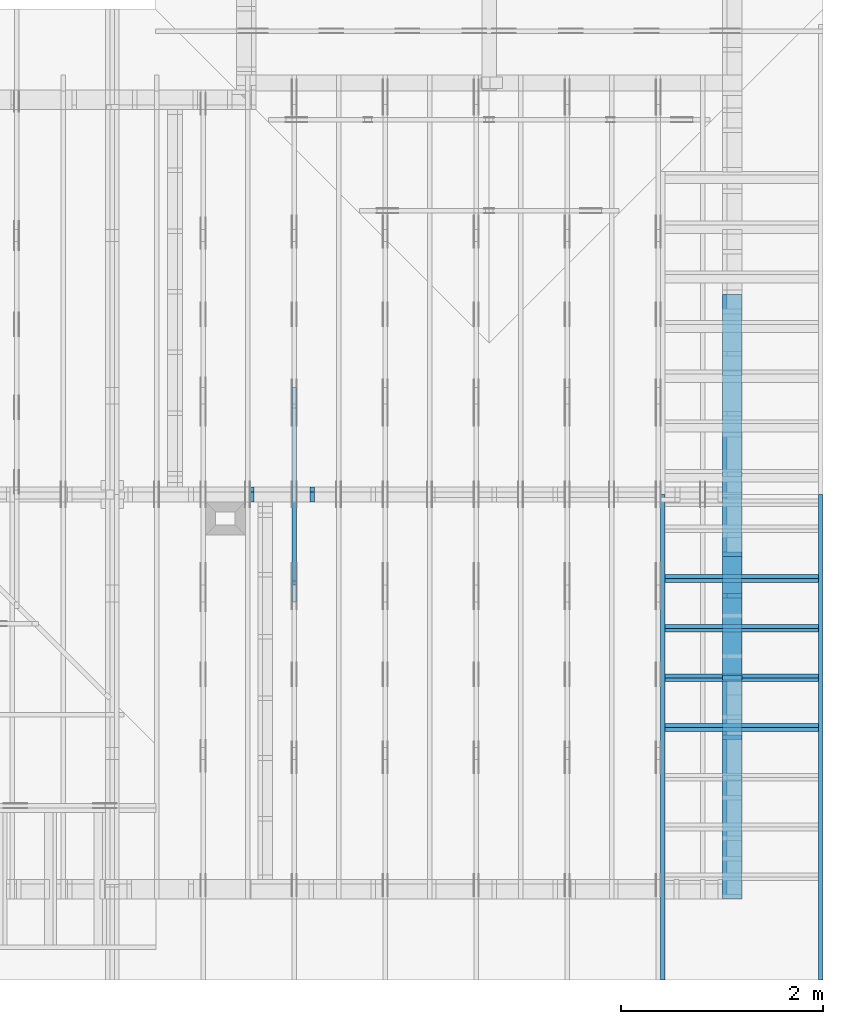
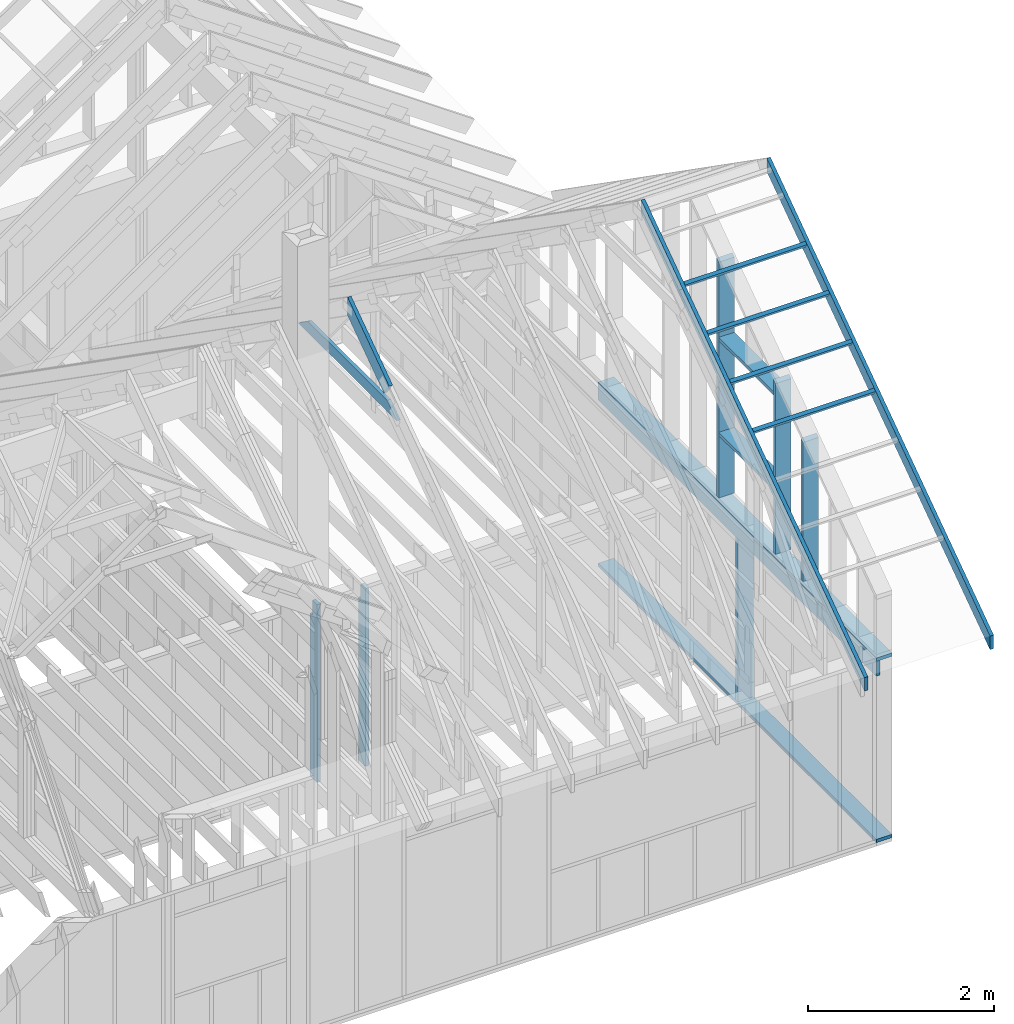
# One storey, part 23 of 70: 19 members, 5 elements without a shape of their own.
"""IFC2X3 building model written with IfcOpenShell, lengths in millimetres."""

from ifc_helpers import new_model, si_unit, frame, origin, origin_with_axes, origin_2d, place, context, project, spatial, faceted_brep, element, aggregate, save


model = new_model("IFC2X3")

# Units and contexts
model_context = context("Model", 3, precision=1e-05, world=origin())
plan_context = context("Plan", 2, precision=1e-05, world=origin_2d())
ifc_project = project(units=[si_unit("LENGTHUNIT", "METRE", prefix="MILLI"), si_unit("AREAUNIT", "SQUARE_METRE"), si_unit("VOLUMEUNIT", "CUBIC_METRE"), si_unit("SOLIDANGLEUNIT", "STERADIAN"), si_unit("PLANEANGLEUNIT", "RADIAN"), si_unit("MASSUNIT", "GRAM"), si_unit("TIMEUNIT", "SECOND"), si_unit("THERMODYNAMICTEMPERATUREUNIT", "DEGREE_CELSIUS"), si_unit("LUMINOUSINTENSITYUNIT", "LUMEN")], contexts=[model_context, plan_context])

# Site, building, storey
site_placement = place(None, origin_with_axes())
site = spatial("IfcSite", under=ifc_project, at=site_placement, CompositionType="ELEMENT")
building_placement = place(site_placement, origin_with_axes())
building = spatial("IfcBuilding", under=site, at=building_placement, Name="Layout 1", CompositionType="ELEMENT")
storey_placement = place(building_placement, origin_with_axes())
storey = spatial("IfcBuildingStorey", under=building, at=storey_placement, Name="Storey 1", CompositionType="ELEMENT", Elevation=0.0)

# Assembly, members
assembly_1_placement = place(storey_placement, frame((12000.0, 0.0, -2470.0), z_axis=(1.0, -6.123031769111886e-17, 6.123031769111886e-17), x_axis=(6.123031769111886e-17, 1.0, 0.0)))
assembly_1 = element("IfcElementAssembly", 1, at=assembly_1_placement, inside=storey, Name="VE5", AssemblyPlace="FACTORY", PredefinedType="NOTDEFINED")
member_1_placement = place(assembly_1_placement, frame((1.457281561048629e-13, 2425.0, -195.0), z_axis=(0.0, 0.0, 1.0), x_axis=(1.0, 0.0, 0.0)))
member_1 = element("IfcMember", 2, at=member_1_placement, Name="P1", context=model_context, shape_type="Brep", body=[
    faceted_brep([(5980.0, 45.0, 195.0), (2.755364296100349e-15, 45.0, 195.0), (0.0, 0.0, 195.0), (5980.0, 0.0, 195.0), (2.755364296100349e-15, 45.0, 3.3742366240998092e-31), (5980.0, 45.0, 7.323145995857816e-13), (5980.0, 0.0, 7.323145995857816e-13), (0.0, 0.0, 0.0), (0.0, 0.0, 0.0), (1.1939911949768178e-14, -1.462169203776584e-30, 195.0), (1.7450640541968876e-14, 45.0, 195.0), (5.510728592200698e-15, 45.0, -1.6871183120499046e-31), (5980.0, -1.0984718993786724e-12, 6.725978337372286e-29), (5980.0, -1.0865319874289042e-12, 195.0), (2.193253805664876e-30, 1.1939911949768178e-14, 195.0), (0.0, 0.0, 0.0), (5980.0, 45.0, 0.0), (5980.0, 45.0, 195.0), (5980.0, 0.0, 195.0), (5980.0, 0.0, 0.0), (2.755364296100349e-15, 45.0, 0.0), (2.755364296100348e-15, 44.999999999999986, 195.0), (5980.0, 44.99999999999962, 195.0), (5980.0, 44.99999999999963, -2.2482535798798836e-29)], [[[0, 1, 2, 3]], [[4, 5, 6, 7]], [[8, 9, 10, 11]], [[12, 13, 14, 15]], [[16, 17, 18, 19]], [[20, 21, 22, 23]]]),
])
member_2_placement = place(assembly_1_placement, frame((5980.0, 90.0, -195.0), z_axis=(0.0, 0.0, 1.0), x_axis=(-1.0, 1.2246063538223773e-16, 0.0)))
member_2 = element("IfcMember", 3, at=member_2_placement, Name="P1", context=model_context, shape_type="Brep", body=[
    faceted_brep([(5980.0, 45.00000000000074, 195.0), (0.0, 45.00000000000074, 195.0), (0.0, 0.0, 195.0), (5980.0, 0.0, 195.0), (0.0, 45.00000000000074, 0.0), (5980.0, 45.00000000000074, 7.323145995857816e-13), (5980.0, 0.0, 7.323145995857816e-13), (0.0, 0.0, 0.0), (0.0, 0.0, 0.0), (1.1939911949768178e-14, -1.462169203776584e-30, 195.0), (1.7450640541968876e-14, 45.00000000000001, 195.0), (5.5107285922006985e-15, 45.00000000000001, -3.3742366240998097e-31), (5980.0, -1.0984718993786724e-12, 1.1250681111517883e-28), (5980.0, -1.0865319874289042e-12, 195.0), (2.193253805664876e-30, 1.1939911949768178e-14, 195.0), (0.0, 0.0, 0.0), (5980.0, 45.00000000000074, 0.0), (5980.0, 45.00000000000074, 195.0), (5980.0, 7.389644451905042e-13, 195.0), (5980.0, 7.389644451905042e-13, 0.0), (0.0, 45.00000000000001, 0.0), (1.5777218104420236e-30, 44.99999999999999, 195.0), (5980.0, 45.00000000000096, 195.0), (5980.0, 45.000000000000966, 1.3805065841367707e-29)], [[[0, 1, 2, 3]], [[4, 5, 6, 7]], [[8, 9, 10, 11]], [[12, 13, 14, 15]], [[16, 17, 18, 19]], [[20, 21, 22, 23]]]),
])
member_3_placement = place(assembly_1_placement, frame((1.3378824415499132e-13, 2229.9999999981374, -195.0), z_axis=(0.0, 0.0, 1.0), x_axis=(1.0, 0.0, 0.0)))
member_3 = element("IfcMember", 4, at=member_3_placement, Name="L1", context=model_context, shape_type="Brep", body=[
    faceted_brep([(5980.0, 195.00000000186265, 45.0), (1.1939911949871576e-14, 195.00000000186265, 45.0), (0.0, 0.0, 45.0), (5980.0, 0.0, 45.0), (1.1939911949871576e-14, 195.00000000186265, 1.4621692037892461e-30), (5980.0, 195.00000000186265, 7.323145995857816e-13), (5980.0, 0.0, 7.323145995857816e-13), (0.0, 0.0, 0.0), (0.0, 0.0, 0.0), (2.755364296100349e-15, -3.3742366240998092e-31, 45.0), (2.6635188195864806e-14, 195.00000000186265, 45.0), (2.3879823899764457e-14, 195.00000000186265, -7.310846018959277e-31), (5980.0, 1.86317026748279e-09, -3.2153157385149134e-29), (5980.0, 1.8631730228470863e-09, 45.0), (-8.584804067855881e-28, 2.755364296100349e-15, 45.0), (0.0, 0.0, 0.0), (5980.0, 195.00000000186265, 0.0), (5980.0, 195.00000000186265, 45.0), (5980.0, 1.862645149230957e-09, 45.0), (5980.0, 1.862645149230957e-09, 0.0), (1.1939911949871576e-14, 195.00000000186265, 0.0), (1.1939911949871576e-14, 195.00000000186265, 45.0), (5980.0, 195.00000000186228, 45.0), (5980.0, 195.00000000186228, -2.208810534618833e-29)], [[[0, 1, 2, 3]], [[4, 5, 6, 7]], [[8, 9, 10, 11]], [[12, 13, 14, 15]], [[16, 17, 18, 19]], [[20, 21, 22, 23]]]),
])
member_4_placement = place(assembly_1_placement, frame((2977.5000000018335, 2425.0, -195.0), z_axis=(0.0, 0.0, 1.0), x_axis=(-1.836909530733566e-16, -1.0, 0.0)))
member_4 = element("IfcMember", 5, at=member_4_placement, Name="S11", context=model_context, shape_type="Brep", body=[
    faceted_brep([(0.0, 44.99999999998545, 45.0), (195.00000000186265, 44.99999999998545, 45.00000000000002), (195.00000000186265, 0.0, 45.00000000000002), (0.0, 0.0, 45.0), (195.00000000186265, 0.0, 0.0), (195.00000000186265, -3.3742366240998092e-31, 45.0), (195.00000000186265, 44.99999999998545, 45.0), (195.00000000186265, 44.99999999998545, 0.0), (2.755364296100349e-15, -3.3742366240998092e-31, 45.0), (1.1939911949768178e-14, -1.462169203776584e-30, 195.0), (1.7450640541967096e-14, 44.99999999998545, 195.00000000000003), (8.266092888299264e-15, 44.99999999998545, 45.0), (2335.0, -4.2891837542628763e-13, 2.626280839091018e-29), (2335.0, -4.1697846347651946e-13, 195.0), (2.193253805664876e-30, 1.1939911949768178e-14, 195.0), (5.061354936149714e-31, 2.755364296100349e-15, 45.0), (195.00000000186265, -3.306437155354634e-14, 45.0), (195.00000000186265, -3.5819735849646686e-14, 2.193253805685826e-30), (-1.6871183120499046e-31, 44.99999999998545, 45.0), (-7.31084601888292e-31, 44.999999999985434, 195.0), (2335.0, 44.99999999998529, 195.0), (2335.0, 44.999999999985306, -8.67746995743113e-30), (195.00000000186265, 44.999999999985434, -7.888609052210118e-31), (195.00000000186265, 44.999999999985434, 45.0), (2335.0, 44.9999999999859, 2.842170943040401e-14), (2335.0, 44.9999999999859, 195.0), (2335.0, 4.547473508864641e-13, 195.0), (2335.0, 4.547473508864641e-13, 0.0), (2335.0, 44.9999999999859, 195.0), (0.0, 44.9999999999859, 195.0), (0.0, 0.0, 195.0), (2335.0, 0.0, 195.0), (195.00000000186265, 44.99999999998545, 2.3879823899764457e-14), (2335.0, 44.99999999998545, 2.859455836175251e-13), (2335.0, 4.547473508864641e-13, 2.859455836175251e-13), (195.00000000186265, 4.547473508864641e-13, 2.3879823899764457e-14)], [[[0, 1, 2, 3]], [[4, 5, 6, 7]], [[8, 9, 10, 11]], [[12, 13, 14, 15, 16, 17]], [[18, 19, 20, 21, 22, 23]], [[24, 25, 26, 27]], [[28, 29, 30, 31]], [[32, 33, 34, 35]]]),
])
aggregate(assembly_1, [member_1, member_2, member_3, member_4])

assembly_2_placement = place(storey_placement, frame((-48.55339059327651, 3927.500000000001, -2470.0), z_axis=(0.0, -1.0, 6.123031769111886e-17), x_axis=(1.0, 0.0, 0.0)))
assembly_2 = element("IfcElementAssembly", 6, at=assembly_2_placement, inside=storey, Name="VE8", AssemblyPlace="FACTORY", PredefinedType="NOTDEFINED")
member_5_placement = place(assembly_2_placement, frame((7177.5000000018335, 2425.0, -145.0), z_axis=(0.0, 0.0, 1.0), x_axis=(-1.836909530733566e-16, -1.0, 0.0)))
member_5 = element("IfcMember", 7, at=member_5_placement, Name="B3", context=model_context, shape_type="Brep", body=[
    faceted_brep([(0.0, 45.0, 45.0), (195.00000000186265, 45.0, 45.00000000000002), (195.00000000186265, 1.4551915228366852e-11, 45.00000000000002), (0.0, 1.4551915228366852e-11, 45.0), (195.00000000186265, 1.3642420526593924e-11, 0.0), (195.00000000186265, 1.3642420526593924e-11, 45.0), (195.00000000186265, 45.0, 45.0), (195.00000000186265, 45.0, 0.0), (2.755364296102131e-15, 1.4551915228366852e-11, 45.0), (8.878396065214018e-15, 1.4551915228366852e-11, 145.0), (1.4389124657412933e-14, 45.0, 145.0), (8.266092888301046e-15, 45.0, 45.0), (2335.0, 1.4122996852940564e-11, 2.626280839091018e-29), (2335.0, 1.4131875249005776e-11, 145.0), (1.6308810349815745e-30, 1.4560793624432064e-11, 145.0), (5.061354936149714e-31, 1.4554670592662952e-11, 45.0), (195.00000000186265, 1.4518850856813305e-11, 45.0), (195.00000000186265, 1.4516095492517205e-11, 2.193253805685862e-30), (-1.6871183120499046e-31, 45.0, 45.0), (-5.436270116605248e-31, 44.99999999999999, 145.0), (2335.0, 44.99999999999985, 145.0), (2335.0, 44.99999999999986, -8.67746995743113e-30), (195.00000000186265, 44.999999999999986, -7.888609052210118e-31), (195.00000000186265, 44.999999999999986, 45.0), (2335.0, 45.0, 2.842170943040401e-14), (2335.0, 45.0, 145.0), (2335.0, 0.0, 145.0), (2335.0, 0.0, 0.0), (2335.0, 45.0, 145.0), (0.0, 45.0, 145.0), (0.0, 1.4551915228366852e-11, 145.0), (2335.0, 1.4551915228366852e-11, 145.0), (195.00000000186265, 45.0, 2.3879823899764457e-14), (2335.0, 45.0, 2.859455836175251e-13), (2335.0, 0.0, 2.859455836175251e-13), (195.00000000186265, 0.0, 2.3879823899764457e-14)], [[[0, 1, 2, 3]], [[4, 5, 6, 7]], [[8, 9, 10, 11]], [[12, 13, 14, 15, 16, 17]], [[18, 19, 20, 21, 22, 23]], [[24, 25, 26, 27]], [[28, 29, 30, 31]], [[32, 33, 34, 35]]]),
])
member_6_placement = place(assembly_2_placement, frame((7777.500000001819, 2425.0, -145.0), z_axis=(0.0, 0.0, 1.0), x_axis=(-1.836909530733566e-16, -1.0, 0.0)))
member_6 = element("IfcMember", 8, at=member_6_placement, Name="S42", context=model_context, shape_type="Brep", body=[
    faceted_brep([(0.0, 45.000000000029104, 45.0), (195.00000000186265, 45.000000000029104, 45.00000000000002), (195.00000000186265, 1.4551915228366852e-11, 45.00000000000002), (0.0, 1.4551915228366852e-11, 45.0), (195.00000000186265, 1.3642420526593924e-11, 0.0), (195.00000000186265, 1.3642420526593924e-11, 45.0), (195.00000000186265, 45.000000000026375, 45.0), (195.00000000186265, 45.000000000026375, 0.0), (2.755364296102131e-15, 1.4551915228366852e-11, 45.0), (8.878396065214018e-15, 1.4551915228366852e-11, 145.0), (1.43891246574165e-14, 45.000000000029104, 145.0), (8.26609288830461e-15, 45.000000000029104, 45.0), (2335.0, 1.4122996852940564e-11, 2.626280839091018e-29), (2335.0, 1.4131875249005776e-11, 145.0), (1.6308810349815745e-30, 1.4560793624432064e-11, 145.0), (5.061354936149714e-31, 1.4554670592662952e-11, 45.0), (195.00000000186265, 1.4518850856813305e-11, 45.0), (195.00000000186265, 1.4516095492517205e-11, 2.193253805685862e-30), (-1.6871183120499046e-31, 45.000000000026375, 45.0), (-5.436270116605248e-31, 45.00000000002637, 145.0), (2335.0, 45.000000000026226, 145.0), (2335.0, 45.00000000002623, -8.67746995743113e-30), (195.00000000186265, 45.00000000002636, -7.888609052210118e-31), (195.00000000186265, 45.00000000002636, 45.0), (2335.0, 45.0, 2.842170943040401e-14), (2335.0, 45.0, 145.0), (2335.0, 0.0, 145.0), (2335.0, 0.0, 0.0), (2335.0, 45.0, 145.0), (0.0, 45.0, 145.0), (0.0, 1.4551915228366852e-11, 145.0), (2335.0, 1.4551915228366852e-11, 145.0), (195.00000000186265, 45.000000000026375, 2.3879823899764457e-14), (2335.0, 45.000000000026375, 2.859455836175251e-13), (2335.0, 0.0, 2.859455836175251e-13), (195.00000000186265, 0.0, 2.3879823899764457e-14)], [[[0, 1, 2, 3]], [[4, 5, 6, 7]], [[8, 9, 10, 11]], [[12, 13, 14, 15, 16, 17]], [[18, 19, 20, 21, 22, 23]], [[24, 25, 26, 27]], [[28, 29, 30, 31]], [[32, 33, 34, 35]]]),
])
aggregate(assembly_2, [member_5, member_6])

assembly_3_placement = place(storey_placement, frame((7550.000000000001, 8000.0, -9.081170196248781e-13), z_axis=(-1.0, 1.836909530733566e-16, 6.123031769111886e-17), x_axis=(-1.836909530733566e-16, -1.0, 0.0)))
assembly_3 = element("IfcElementAssembly", 9, at=assembly_3_placement, inside=storey, Name="T3", AssemblyPlace="FACTORY", PredefinedType="TRUSS")
member_7_placement = place(assembly_3_placement, frame((5060.798502586593, 2964.999999998785, -45.0), z_axis=(0.0, 0.0, 1.0), x_axis=(-1.0, 1.2246063538223773e-16, 0.0)))
member_7 = element("IfcMember", 10, at=member_7_placement, Name="C1", context=model_context, shape_type="Brep", body=[
    faceted_brep([(2121.597005175296, 145.00000000000728, 45.0), (0.0, 145.00000000000728, 45.0), (207.08146097743884, 0.0, 45.0), (1914.5155441979737, 0.0, 45.0), (0.0, 145.00000000000728, 0.0), (2121.597005175296, 145.00000000000728, 2.5981211727881944e-13), (1914.5155441979737, 0.0, 2.3445278999165447e-13), (207.08146097743884, 0.0, 2.5359327287179227e-14), (207.08146097743878, -7.105427357601002e-14, 3.1554436208840472e-30), (207.08146097743878, -7.105427357601002e-14, 45.0), (1.4210854715202004e-14, 145.00000000000728, 45.0), (1.4210854715202004e-14, 145.00000000000728, 0.0), (1914.5155441979737, 7.26803319922997e-12, 4.8521444511629875e-31), (1914.5155441979737, 7.27078856352607e-12, 45.0), (207.08146097743884, 1.898228698049977e-15, 45.0), (207.08146097743884, -8.571355980503717e-16, 5.248268497299439e-32), (2121.597005175296, 145.00000000000728, 0.0), (2121.597005175296, 145.00000000000728, 45.0), (1914.515544197974, 7.389644451905042e-12, 45.0), (1914.515544197974, 7.389644451905042e-12, 1.262177448353619e-29), (0.0, 145.00000000000728, 0.0), (-1.6871183120499046e-31, 145.00000000000728, 45.0), (2121.597005175296, 145.00000000000713, 45.0), (2121.597005175296, 145.00000000000713, -7.888609052210118e-30)], [[[0, 1, 2, 3]], [[4, 5, 6, 7]], [[8, 9, 10, 11]], [[12, 13, 14, 15]], [[16, 17, 18, 19]], [[20, 21, 22, 23]]]),
])
member_8_placement = place(assembly_3_placement, frame((3888.1525949105694, 3641.0955042035366, -45.00000000000001), z_axis=(0.0, 0.0, 1.0), x_axis=(0.8191520442889916, -0.5735764363510465, 0.0)))
member_8 = element("IfcMember", 11, at=member_8_placement, Name="T18", context=model_context, shape_type="Brep", body=[
    faceted_brep([(1091.5642005560503, 194.99999999996362, 45.0), (0.0, 194.99999999996362, 45.0), (136.54046995208614, 0.0, 45.0), (1091.5642005561149, 0.0, 45.0), (0.0, 194.99999999996362, 0.0), (1091.5642005560503, 194.99999999996362, 1.336736455605983e-13), (1091.5642005561149, 0.0, 1.336736455606062e-13), (136.54046995208614, 0.0, 1.6720832705721806e-14), (136.54046995208614, -2.842170943040401e-14, 3.0619884913871384e-31), (136.54046995208614, -2.842170943040401e-14, 45.0), (1.4210854715202004e-14, 195.00000000170263, 45.0), (1.4210854715202004e-14, 195.00000000170263, -5.932810329456638e-31), (1091.5642005561149, 2.0525182992035534e-09, 1.2934457505131873e-29), (1091.5642005561149, 2.0525210545678495e-09, 45.0), (136.54046995208614, -2.3668346958569874e-14, 45.0), (136.54046995208614, -2.6423711254670222e-14, 1.6179322347011683e-30), (1091.5642005561149, 194.99999999996362, 3.950615413346827e-27), (1091.5642005561149, 194.99999999996362, 45.0), (1091.5642005561149, 2.052729541901499e-09, 45.0), (1091.5642005561149, 2.052729541901499e-09, 0.0), (0.0, 195.00000000170257, 0.0), (0.0, 195.00000000170257, 45.0), (1091.5642005560503, 194.9999999999637, 45.0), (1091.5642005560503, 194.9999999999637, 6.310887241768095e-30)], [[[0, 1, 2, 3]], [[4, 5, 6, 7]], [[8, 9, 10, 11]], [[12, 13, 14, 15]], [[16, 17, 18, 19]], [[20, 21, 22, 23]]]),
])
aggregate(assembly_3, [member_7, member_8])

assembly_4_placement = place(storey_placement, frame((11805.0, 8000.000000000002, 1.1939911949768178e-14), z_axis=(-1.0, 1.836909530733566e-16, 6.123031769111886e-17), x_axis=(-1.836909530733566e-16, -1.0, 0.0)))
assembly_4 = element("IfcElementAssembly", 12, at=assembly_4_placement, inside=storey, Name="VE9", AssemblyPlace="FACTORY", PredefinedType="NOTDEFINED")
member_9_placement = place(assembly_4_placement, frame((6377.500000001819, 1904.1395588799205, -195.0), z_axis=(0.0, 0.0, 1.0), x_axis=(-1.836909530733566e-16, -1.0, 0.0)))
member_9 = element("IfcMember", 13, at=member_9_placement, Name="S16", context=model_context, shape_type="Brep", body=[
    faceted_brep([(1859.1395588799205, 45.0, 195.0), (31.509339219453977, 45.0, 195.0), (0.0, 2.9103830456733704e-11, 195.0), (1859.1395588799205, 2.9103830456733704e-11, 195.0), (31.509339219453977, 45.0, 3.8586537012887966e-15), (1859.1395588799205, 45.0, 2.276714116446882e-13), (1859.1395588799205, 2.9103830456733704e-11, 2.276714116446882e-13), (0.0, 2.9103830456733704e-11, 0.0), (-7.619909064937699e-16, 2.910436400851048e-11, 5.695761319002778e-32), (9.018612375785889e-15, 2.9097515556363982e-11, 195.0), (31.509339219454002, 45.00000000001455, 195.0), (31.50933921945399, 45.00000000001456, -4.25550513074153e-31), (1859.1395588799205, -9.601340980765327e-13, 5.878931585130203e-29), (1859.1395588799205, -9.481941861267645e-13, 195.0), (1.9307915208993223e-28, 2.911577036868347e-11, 195.0), (0.0, 2.9103830456733704e-11, 0.0), (1859.1395588799205, 45.0, 0.0), (1859.1395588799205, 45.0, 195.0), (1859.1395588799205, 0.0, 195.0), (1859.1395588799205, 0.0, 0.0), (31.509339219453977, 45.000000000014545, 0.0), (31.509339219453977, 45.00000000001454, 195.0), (1859.1395588799205, 44.999999999999815, 195.0), (1859.1395588799205, 44.99999999999982, -1.064962222048366e-29)], [[[0, 1, 2, 3]], [[4, 5, 6, 7]], [[8, 9, 10, 11]], [[12, 13, 14, 15]], [[16, 17, 18, 19]], [[20, 21, 22, 23]]]),
])
member_10_placement = place(assembly_4_placement, frame((4567.500000003639, 3171.515203039329, -195.0), z_axis=(0.0, 0.0, 1.0), x_axis=(-1.836909530733566e-16, -1.0, 0.0)))
member_10 = element("IfcMember", 14, at=member_10_placement, Name="S6", context=model_context, shape_type="Brep", body=[
    faceted_brep([(3126.515203039329, 45.0, 195.0), (31.509339219461253, 45.0, 195.0), (0.0, 2.8194335754960775e-11, 195.0), (3126.515203039329, 2.8194335754960775e-11, 195.0), (31.509339219461253, 45.0, 3.858653701289688e-15), (3126.515203039329, 45.0, 3.8287503829642225e-13), (3126.515203039329, 2.8194335754960775e-11, 3.8287503829642225e-13), (0.0, 2.8194335754960775e-11, 0.0), (2.6267547142647803e-15, 2.8192496481508815e-11, -1.9634575384670695e-31), (1.2407357996544439e-14, 2.8185648029362317e-11, 195.0), (31.509339219461275, 45.000000000013635, 195.0), (31.509339219461264, 45.00000000001364, -8.003868105088243e-32), (3126.515203039329, -1.490101245227334e-13, 9.123937263720071e-30), (3126.515203039329, -1.3707021257296523e-13, 195.0), (1.082409750747023e-28, 2.8206275666910544e-11, 195.0), (0.0, 2.8194335754960775e-11, 0.0), (3126.515203039329, 45.0, 0.0), (3126.515203039329, 45.0, 195.0), (3126.515203039329, 0.0, 195.0), (3126.515203039329, 0.0, 0.0), (31.509339219461253, 45.00000000001364, 0.0), (31.509339219461253, 45.00000000001363, 195.0), (3126.515203039329, 44.999999999999694, 195.0), (3126.515203039329, 44.99999999999971, -1.7749370367472766e-29)], [[[0, 1, 2, 3]], [[4, 5, 6, 7]], [[8, 9, 10, 11]], [[12, 13, 14, 15]], [[16, 17, 18, 19]], [[20, 21, 22, 23]]]),
])
member_11_placement = place(assembly_4_placement, frame((5787.5000000036525, 2317.262006422745, -195.0), z_axis=(0.0, 0.0, 1.0), x_axis=(-1.836909530733566e-16, -1.0, 0.0)))
member_11 = element("IfcMember", 15, at=member_11_placement, Name="S13", context=model_context, shape_type="Brep", body=[
    faceted_brep([(2272.262006422745, 45.0, 195.0), (31.50933921946853, 45.0, 195.0), (0.0, 0.0, 195.0), (2272.262006422745, 0.0, 195.0), (31.50933921946853, 45.0, 3.858653701290579e-15), (2272.262006422745, 45.0, 2.7826264906144766e-13), (2272.262006422745, 0.0, 2.7826264906144766e-13), (0.0, 0.0, 0.0), (-2.9102126727622445e-15, 2.037752851262935e-15, 2.175337872185383e-31), (6.870390609518735e-15, -4.810699295233489e-15, 195.0), (31.509339219468536, 45.00000000001454, 195.0), (31.509339219468526, 45.000000000014545, 2.0318560913285338e-32), (2272.262006422745, -4.1739397359217154e-13, 2.555716560540714e-29), (2272.262006422745, -4.0545406164240336e-13, 195.0), (2.193253805664876e-30, 1.1939911949768178e-14, 195.0), (0.0, 0.0, 0.0), (2272.262006422745, 45.0, 0.0), (2272.262006422745, 45.0, 195.0), (2272.262006422745, 0.0, 195.0), (2272.262006422745, 0.0, 0.0), (31.50933921946853, 45.00000000001455, 0.0), (31.50933921946853, 45.00000000001454, 195.0), (2272.262006422745, 44.99999999999998, 195.0), (2272.262006422745, 44.999999999999986, -7.888609052210118e-31)], [[[0, 1, 2, 3]], [[4, 5, 6, 7]], [[8, 9, 10, 11]], [[12, 13, 14, 15]], [[16, 17, 18, 19]], [[20, 21, 22, 23]]]),
])
member_12_placement = place(assembly_4_placement, frame((5787.500000001819, 2154.9999999987917, -195.0), z_axis=(0.0, 0.0, 1.0), x_axis=(-1.0, 1.2246063538223773e-16, 0.0)))
member_12 = element("IfcMember", 16, at=member_12_placement, Name="S25", context=model_context, shape_type="Brep", body=[
    faceted_brep([(1175.0, 45.0, 195.0), (0.0, 45.0, 195.0), (0.0, 1.4097167877480388e-11, 195.0), (1175.0, 1.4097167877480388e-11, 195.0), (0.0, 45.0, 0.0), (1175.0, 45.0, 1.4389124657412933e-13), (1175.0, 1.4097167877480388e-11, 1.4389124657412933e-13), (0.0, 1.4097167877480388e-11, 0.0), (1.72634813536632e-27, 1.4097167877480388e-11, -1.0570484477395044e-43), (1.1939911949769904e-14, 1.4097167877480388e-11, 195.0), (1.7450640541970602e-14, 45.0000000000141, 195.0), (5.510728592202424e-15, 45.0000000000141, -3.3742366241008663e-31), (1175.0, 3.1440564669978077e-13, -1.9251157631309254e-29), (1175.0, 3.2634555864954895e-13, 195.0), (1.4005529145541352e-28, 1.4109107789430156e-11, 195.0), (0.0, 1.4097167877480388e-11, 0.0), (1175.0, 45.0, 0.0), (1175.0, 45.0, 195.0), (1175.0, 0.0, 195.0), (1175.0, 0.0, 0.0), (0.0, 45.0000000000141, 0.0), (-1.0097419586828951e-28, 45.00000000001408, 195.0), (1175.0, 45.000000000000185, 195.0), (1175.0, 45.0000000000002, 1.1832913578315177e-29)], [[[0, 1, 2, 3]], [[4, 5, 6, 7]], [[8, 9, 10, 11]], [[12, 13, 14, 15]], [[16, 17, 18, 19]], [[20, 21, 22, 23]]]),
])
member_13_placement = place(assembly_4_placement, frame((4612.500000001819, 863.1713847472129, -195.0), z_axis=(0.0, 0.0, 1.0), x_axis=(1.0, 0.0, 0.0)))
member_13 = element("IfcMember", 17, at=member_13_placement, Name="S25", context=model_context, shape_type="Brep", body=[
    faceted_brep([(1175.0, 45.00000000001455, 195.0), (0.0, 45.00000000001455, 195.0), (0.0, 0.0, 195.0), (1175.0, 0.0, 195.0), (0.0, 45.00000000001455, 0.0), (1175.0, 45.00000000001455, 1.4389124657412933e-13), (1175.0, 0.0, 1.4389124657412933e-13), (0.0, 0.0, 0.0), (0.0, 0.0, 0.0), (1.1939911949768178e-14, -1.462169203776584e-30, 195.0), (1.7450640541968876e-14, 45.0, 195.0), (5.510728592200698e-15, 45.0, -3.3742366240998092e-31), (1175.0, -2.15836869861194e-13, 1.3215760111057586e-29), (1175.0, -2.0389695791142581e-13, 195.0), (2.193253805664876e-30, 1.1939911949768178e-14, 195.0), (0.0, 0.0, 0.0), (1175.0, 45.00000000001455, 0.0), (1175.0, 45.00000000001455, 195.0), (1175.0, 0.0, 195.0), (1175.0, 0.0, 0.0), (0.0, 45.0, 0.0), (1.0097419586828951e-28, 44.999999999999986, 195.0), (1175.0, 45.00000000001452, 195.0), (1175.0, 45.00000000001454, -7.888609052210118e-31)], [[[0, 1, 2, 3]], [[4, 5, 6, 7]], [[8, 9, 10, 11]], [[12, 13, 14, 15]], [[16, 17, 18, 19]], [[20, 21, 22, 23]]]),
])
aggregate(assembly_4, [member_9, member_10, member_11, member_12, member_13])

assembly_5_placement = place(storey_placement, frame((12800.0, -800.0, 439.83396943223215), z_axis=(-2.4046889635939937e-17, -0.573576436351046, 0.8191520442889918), x_axis=(1.5036672491230068e-17, 0.8191520442889918, 0.573576436351046)))
assembly_5 = element("IfcElementAssembly", 18, at=assembly_5_placement, inside=storey, Name="gs2", AssemblyPlace="FACTORY", PredefinedType="TRUSS")
member_14_placement = place(assembly_5_placement, frame((-101.53009304040826, 1560.0, -145.0), z_axis=(0.0, 0.0, 1.0), x_axis=(1.0, 0.0, 0.0)))
member_14 = element("IfcMember", 19, at=member_14_placement, Name="T1", context=model_context, shape_type="Brep", body=[
    faceted_brep([(1.7129846197979795e-15, 1.2433439704018187e-14, 2.722226468679651e-14), (101.53009303936366, -5.959205434536614e-31, 145.00000000000057), (101.53009303936324, 45.0, 144.99999999999997), (5.410739007390032e-15, 45.000000000000014, 2.4633069190183164e-14), (5961.248119095398, -1.0861489524381756e-12, 145.0), (101.53009303936454, -9.771763490815204e-15, 145.0), (1.4210854715202004e-14, -2.6104054466224595e-30, 1.5983595479932022e-46), (5859.718026053387, -1.0763771889468743e-12, 6.59069172346906e-29), (5859.718026053308, 45.0, 5.5933924159035087e-11), (5961.248119095399, 45.0, 145.0), (5961.248119095399, 0.0, 145.0), (5859.718026053308, 0.0, 5.5933924159035087e-11), (1.4210854715202004e-14, 45.0, 0.0), (101.53009303936325, 44.999999999999986, 145.0), (5961.248119095398, 44.99999999999962, 145.0), (5859.718026053387, 44.999999999999645, -2.208810534618833e-29), (1.4210854715202004e-14, 45.0, 1.7402702977483063e-30), (5859.718026053387, 45.0, 7.175847926312496e-13), (5859.718026053387, 0.0, 7.175847926312496e-13), (1.4210854715202004e-14, 0.0, 1.7402702977483063e-30), (5961.248119095398, 45.0, 145.0), (101.53009303936325, 45.0, 145.0), (101.53009303936454, 0.0, 145.0), (5961.248119095398, 0.0, 145.0)], [[[0, 1, 2, 3]], [[4, 5, 6, 7]], [[8, 9, 10, 11]], [[12, 13, 14, 15]], [[16, 17, 18, 19]], [[20, 21, 22, 23]]]),
])
member_15_placement = place(assembly_5_placement, frame((5859.718026054989, 45.0, -145.00000000007577), z_axis=(0.0, 0.0, 1.0), x_axis=(-1.0, 1.2246063538223773e-16, 0.0)))
member_15 = element("IfcMember", 20, at=member_15_placement, Name="T1", context=model_context, shape_type="Brep", body=[
    faceted_brep([(5961.248119095399, 45.00000000000072, 7.548806024715304e-11), (5859.718026056034, 45.00000000000072, 145.00000000007685), (5859.718026056035, 7.176481631177012e-13, 145.00000000007594), (5961.248119095399, 7.176481631177012e-13, 7.548806024715304e-11), (-5.436270116608089e-31, 45.00000000000071, 145.00000000007577), (5859.7180260560335, 45.00000000000035, 145.00000000007577), (5961.248119095398, 45.000000000000355, 7.577227734145708e-11), (101.53009304201078, 45.00000000000071, 7.577227734145708e-11), (101.53009304190255, -1.2433439704329101e-14, 7.105427357601002e-15), (-1.4210854715202004e-14, 1.4730632452127507e-30, 145.00000000007577), (-1.4210854715202004e-14, 45.0, 145.00000000007577), (101.53009304190255, 44.999999999999986, 7.105427357601002e-15), (5961.248119095398, -3.6316833067048e-13, 7.577227734145708e-11), (5859.718026056034, -3.356397750492407e-13, 145.00000000007577), (1.6308810349824268e-30, 7.407374138981201e-13, 145.00000000007577), (101.53009304201078, 7.132088582763943e-13, 7.577227734145708e-11), (101.53009304201078, 45.000000000000014, 7.578471078116143e-11), (5961.248119095398, 45.000000000000014, 7.650229557379267e-11), (5961.248119095398, 7.318590178329032e-13, 7.650229557379267e-11), (101.53009304201078, 7.318590178329032e-13, 7.578471078116143e-11), (5859.7180260560335, 45.00000000000072, 145.00000000007577), (0.0, 45.00000000000072, 145.00000000007577), (0.0, 0.0, 145.00000000007577), (5859.718026056034, 0.0, 145.00000000007577)], [[[0, 1, 2, 3]], [[4, 5, 6, 7]], [[8, 9, 10, 11]], [[12, 13, 14, 15]], [[16, 17, 18, 19]], [[20, 21, 22, 23]]]),
])
member_16_placement = place(assembly_5_placement, frame((3044.9999999994034, 45.0, -70.0), z_axis=(0.0, 0.0, 1.0), x_axis=(6.123031769111886e-17, 1.0, 0.0)))
member_16 = element("IfcMember", 21, at=member_16_placement, Name="W5", context=model_context, shape_type="Brep", body=[
    faceted_brep([(1514.9999999999982, 45.00000000001455, 70.0), (0.0, 45.00000000001455, 70.0), (0.0, 2.9103830456733704e-11, 70.0), (1514.9999999999982, 2.9103830456733704e-11, 70.0), (0.0, 45.00000000001455, 0.0), (1514.9999999999982, 45.00000000001455, 1.8552786260408993e-13), (1514.9999999999982, 2.9103830456733704e-11, 1.8552786260408993e-13), (0.0, 2.9103830456733704e-11, 0.0), (3.564073569788531e-27, 2.9103830456733704e-11, -2.1822935695267187e-43), (4.2861222383818845e-15, 2.9103830456733704e-11, 70.0), (9.796850830582582e-15, 45.000000000029104, 70.0), (5.510728592204262e-15, 45.000000000029104, -3.3742366241019913e-31), (1514.9999999999982, -7.774480657775668e-13, 4.7603392055906514e-29), (1514.9999999999982, -7.731619435391885e-13, 70.0), (8.453782995809386e-29, 2.910811657897208e-11, 70.0), (0.0, 2.9103830456733704e-11, 0.0), (1514.9999999999982, 45.00000000001455, 0.0), (1514.9999999999982, 45.00000000001455, 70.0), (1514.9999999999982, 0.0, 70.0), (1514.9999999999982, 0.0, 0.0), (0.0, 45.000000000029104, 0.0), (-5.048709793414476e-29, 45.0000000000291, 70.0), (1514.9999999999982, 45.000000000014545, 70.0), (1514.9999999999982, 45.000000000014545, -3.944304526105059e-31)], [[[0, 1, 2, 3]], [[4, 5, 6, 7]], [[8, 9, 10, 11]], [[12, 13, 14, 15]], [[16, 17, 18, 19]], [[20, 21, 22, 23]]]),
])
member_17_placement = place(assembly_5_placement, frame((3644.999999999389, 45.0, -70.0), z_axis=(0.0, 0.0, 1.0), x_axis=(6.123031769111886e-17, 1.0, 0.0)))
member_17 = element("IfcMember", 22, at=member_17_placement, Name="W5", context=model_context, shape_type="Brep", body=[
    faceted_brep([(1514.9999999999982, 44.99999999998545, 70.0), (0.0, 44.99999999998545, 70.0), (0.0, 0.0, 70.0), (1514.9999999999982, 0.0, 70.0), (0.0, 44.99999999998545, 0.0), (1514.9999999999982, 44.99999999998545, 1.8552786260408993e-13), (1514.9999999999982, 0.0, 1.8552786260408993e-13), (0.0, 0.0, 0.0), (0.0, 0.0, 0.0), (4.2861222383783204e-15, -5.248812526377481e-31, 70.0), (9.796850830579018e-15, 45.0, 70.0), (5.510728592200698e-15, 45.0, -3.3742366240998092e-31), (1514.9999999999982, -2.782917939061349e-13, 1.7039894951704017e-29), (1514.9999999999982, -2.7400567166775656e-13, 70.0), (7.8732187895662216e-31, 4.2861222383783204e-15, 70.0), (0.0, 0.0, 0.0), (1514.9999999999982, 44.99999999998545, 0.0), (1514.9999999999982, 44.99999999998545, 70.0), (1514.9999999999982, 0.0, 70.0), (1514.9999999999982, 0.0, 0.0), (0.0, 45.0, 0.0), (-5.048709793414476e-29, 44.99999999999999, 70.0), (1514.9999999999982, 44.99999999998544, 70.0), (1514.9999999999982, 44.99999999998544, -3.944304526105059e-31)], [[[0, 1, 2, 3]], [[4, 5, 6, 7]], [[8, 9, 10, 11]], [[12, 13, 14, 15]], [[16, 17, 18, 19]], [[20, 21, 22, 23]]]),
])
member_18_placement = place(assembly_5_placement, frame((4244.999999999403, 44.99999999999999, -70.0), z_axis=(0.0, 0.0, 1.0), x_axis=(6.123031769111886e-17, 1.0, 0.0)))
member_18 = element("IfcMember", 23, at=member_18_placement, Name="W5", context=model_context, shape_type="Brep", body=[
    faceted_brep([(1514.9999999999982, 45.0, 70.0), (0.0, 45.0, 70.0), (7.105427357601002e-15, 1.4551915228366852e-11, 70.0), (1514.9999999999982, 1.4551915228366852e-11, 70.0), (0.0, 45.0, 0.0), (1514.9999999999982, 45.0, 1.8552786260408993e-13), (1514.9999999999982, 1.4551915228366852e-11, 1.8552786260408993e-13), (7.105427357601002e-15, 1.4551915228366852e-11, 8.701351488741532e-31), (7.105427357605082e-15, 1.4551915228366852e-11, -2.4978145126589864e-43), (1.1391549595983402e-14, 1.4551915228366852e-11, 70.0), (1.69022781881841e-14, 45.00000000001455, 70.0), (1.261615594980578e-14, 45.00000000001455, -7.724912368473073e-31), (1514.9999999999982, -5.27869929841851e-13, 3.2321643503805275e-29), (1514.9999999999982, -5.235838076034727e-13, 70.0), (7.105427357601044e-15, 1.455620135060523e-11, 70.0), (7.105427357601002e-15, 1.4551915228366852e-11, 0.0), (1514.9999999999982, 45.0, 0.0), (1514.9999999999982, 45.0, 70.0), (1514.9999999999982, 0.0, 70.0), (1514.9999999999982, 0.0, 0.0), (0.0, 45.00000000001455, 0.0), (-5.048709793414476e-29, 45.000000000014545, 70.0), (1514.9999999999982, 44.99999999999999, 70.0), (1514.9999999999982, 44.99999999999999, -3.944304526105059e-31)], [[[0, 1, 2, 3]], [[4, 5, 6, 7]], [[8, 9, 10, 11]], [[12, 13, 14, 15]], [[16, 17, 18, 19]], [[20, 21, 22, 23]]]),
])
member_19_placement = place(assembly_5_placement, frame((4844.999999999403, 44.99999999999999, -70.0), z_axis=(0.0, 0.0, 1.0), x_axis=(6.123031769111886e-17, 1.0, 0.0)))
member_19 = element("IfcMember", 24, at=member_19_placement, Name="W5", context=model_context, shape_type="Brep", body=[
    faceted_brep([(1514.9999999999982, 45.00000000001455, 70.0), (0.0, 45.00000000001455, 70.0), (7.105427357601002e-15, 2.9103830456733704e-11, 70.0), (1514.9999999999982, 2.9103830456733704e-11, 70.0), (0.0, 45.00000000001455, 0.0), (1514.9999999999982, 45.00000000001455, 1.8552786260408993e-13), (1514.9999999999982, 2.9103830456733704e-11, 1.8552786260408993e-13), (7.105427357601002e-15, 2.9103830456733704e-11, 8.701351488741532e-31), (7.10542735760916e-15, 2.9103830456733704e-11, -4.995629025317973e-43), (1.139154959598748e-14, 2.9103830456733704e-11, 70.0), (1.690227818818818e-14, 45.000000000029104, 70.0), (1.2616155949809858e-14, 45.000000000029104, -7.724912368475571e-31), (1514.9999999999982, -7.774480657775668e-13, 4.7603392055906514e-29), (1514.9999999999982, -7.731619435391885e-13, 70.0), (7.105427357601087e-15, 2.910811657897208e-11, 70.0), (7.105427357601002e-15, 2.9103830456733704e-11, 0.0), (1514.9999999999982, 45.00000000001455, 0.0), (1514.9999999999982, 45.00000000001455, 70.0), (1514.9999999999982, 0.0, 70.0), (1514.9999999999982, 0.0, 0.0), (0.0, 45.000000000029104, 0.0), (-5.048709793414476e-29, 45.0000000000291, 70.0), (1514.9999999999982, 45.000000000014545, 70.0), (1514.9999999999982, 45.000000000014545, -3.944304526105059e-31)], [[[0, 1, 2, 3]], [[4, 5, 6, 7]], [[8, 9, 10, 11]], [[12, 13, 14, 15]], [[16, 17, 18, 19]], [[20, 21, 22, 23]]]),
])
aggregate(assembly_5, [member_14, member_15, member_16, member_17, member_18, member_19])

save(model, "model.ifc")
